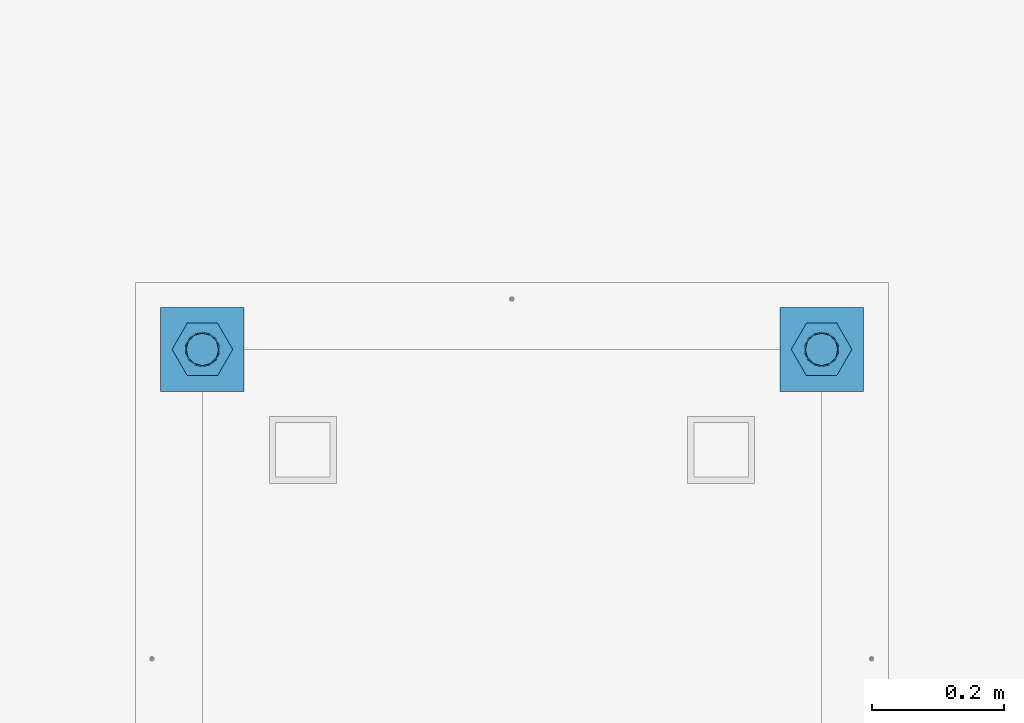
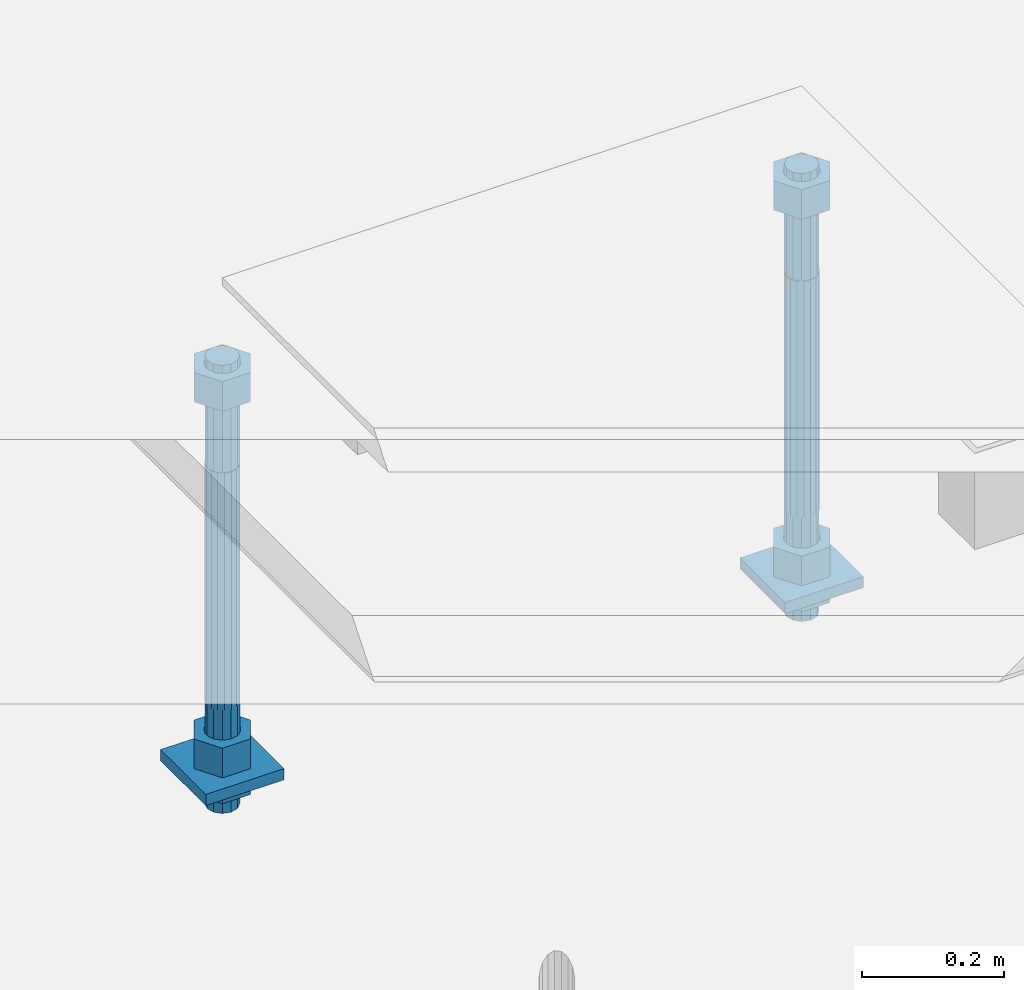
# One storey, part 2583 of 3843: 10 beams, 1 element without a shape of its own.
"""IFC2X3 building model written with IfcOpenShell, lengths in millimetres."""

from ifc_helpers import new_model, si_unit, frame, origin_with_axes, place, context, subcontext, project, spatial, faceted_brep, material, type_object, element, aggregate, save


model = new_model("IFC2X3")

# Units and contexts
model_context = context("Model", 3, precision=1e-05, world=origin_with_axes())
body_context = subcontext(model_context, "Body", "Model", "MODEL_VIEW")
ifc_project = project(units=[si_unit("LENGTHUNIT", "METRE", prefix="MILLI"), si_unit("AREAUNIT", "SQUARE_METRE"), si_unit("VOLUMEUNIT", "CUBIC_METRE"), si_unit("MASSUNIT", "GRAM", prefix="KILO"), si_unit("TIMEUNIT", "SECOND"), si_unit("PLANEANGLEUNIT", "RADIAN"), si_unit("SOLIDANGLEUNIT", "STERADIAN"), si_unit("THERMODYNAMICTEMPERATUREUNIT", "DEGREE_CELSIUS"), si_unit("LUMINOUSINTENSITYUNIT", "LUMEN")], contexts=[model_context])

# Site, building, storey
site_placement = place(None, origin_with_axes())
site = spatial("IfcSite", under=ifc_project, at=site_placement, CompositionType="ELEMENT")
building_placement = place(site_placement, origin_with_axes())
building = spatial("IfcBuilding", under=site, at=building_placement, Name="Undefined", CompositionType="ELEMENT")
storey_placement = place(building_placement, origin_with_axes())
storey = spatial("IfcBuildingStorey", under=building, at=storey_placement, Name="Undefined", CompositionType="ELEMENT", Elevation=0.0)

# Assembly, beams
assembly_placement = place(storey_placement, origin_with_axes())
assembly = element("IfcElementAssembly", 1, at=assembly_placement, inside=storey, Name="TEMPLATE", AssemblyPlace="NOTDEFINED", PredefinedType="RIGID_FRAME")
ifc_material_1 = material(Name="STEEL/A36")
beam_type_1 = type_object("IfcBeamType", PredefinedType="NOTDEFINED")
beam_1_placement = place(assembly_placement, frame((108483.4, 15176.5000015259, 29244.925), z_axis=(1.0, 0.0, 0.0), x_axis=(0.0, 1.0, 0.0)))
beam_1 = element("IfcBeam", 2, at=beam_1_placement, type_object=beam_type_1, material=ifc_material_1, Name="WASHER_PLATE", context=body_context, shape_type="Brep", body=[
    faceted_brep([(0.0, 9.52500000000146, -63.5), (0.0, 9.52500000000146, 63.5), (127.0, 9.52500000000146, 63.5), (127.0, 9.52500000000146, -63.5), (0.0, -9.52500000000146, 63.5), (127.0, -9.52500000000146, 63.5), (0.0, -9.52500000000146, -63.5), (127.0, -9.52500000000146, -63.5)], [[[0, 1, 2, 3]], [[1, 4, 5, 2]], [[4, 6, 7, 5]], [[6, 0, 3, 7]], [[5, 7, 3, 2]], [[6, 4, 1, 0]]]),
])
beam_2_placement = place(assembly_placement, frame((109423.2, 15176.5000015259, 29244.925), z_axis=(1.0, 0.0, 0.0), x_axis=(0.0, 1.0, 0.0)))
beam_2 = element("IfcBeam", 3, at=beam_2_placement, type_object=beam_type_1, material=ifc_material_1, Name="WASHER_PLATE", context=body_context, shape_type="Brep", body=[
    faceted_brep([(0.0, 9.52500000000146, -63.5), (0.0, 9.52500000000146, 63.5), (127.0, 9.52500000000146, 63.5), (127.0, 9.52500000000146, -63.5), (0.0, -9.52500000000146, 63.5), (127.0, -9.52500000000146, 63.5), (0.0, -9.52500000000146, -63.5), (127.0, -9.52500000000146, -63.5)], [[[0, 1, 2, 3]], [[1, 4, 5, 2]], [[4, 6, 7, 5]], [[6, 0, 3, 7]], [[5, 7, 3, 2]], [[6, 4, 1, 0]]]),
])
beam_type_2 = type_object("IfcBeamType", Name="2_HALF_NUT", PredefinedType="NOTDEFINED")
beam_3_placement = place(assembly_placement, frame((108483.4, 15240.0000015259, 29235.4), z_axis=(0.0, -1.0, 0.0), x_axis=(0.0, 0.0, -1.0)))
beam_3 = element("IfcBeam", 4, at=beam_3_placement, type_object=beam_type_2, material=ifc_material_1, Name="NUT", ObjectType="2_HALF_NUT", context=body_context, shape_type="Brep", body=[
    faceted_brep([(0.0, -46.0369987487793, 0.0), (0.0, -23.0184993743896, -39.869213104248), (25.4000000000015, -23.0184993743896, -39.869213104248), (25.4000000000015, -46.0369987487793, 0.0), (0.0, 23.0184993743896, -39.869213104248), (25.4000000000015, 23.0184993743896, -39.869213104248), (0.0, 46.0369987487793, 0.0), (25.4000000000015, 46.0369987487793, 0.0), (0.0, 23.0184993743896, 39.869213104248), (25.4000000000015, 23.0184993743896, 39.869213104248), (0.0, -23.0184993743896, 39.869213104248), (25.4000000000015, -23.0184993743896, 39.869213104248), (0.0, 0.0, 26.1940002441406), (0.0, 11.3650617044477, 23.5999013092805), (25.4000000000015, 11.3650617044477, 23.5999013092805), (25.4000000000015, 0.0, 26.1940002441406), (0.0, 20.4791109456419, 16.3316083006721), (25.4000000000015, 20.4791109456419, 16.3316083006721), (0.0, 25.5370200498292, 5.82867859874386), (25.4000000000015, 25.5370200498292, 5.82867859874386), (0.0, 25.5370200498292, -5.82867859874386), (25.4000000000015, 25.5370200498292, -5.82867859874386), (0.0, 20.4791109456419, -16.3316083006721), (25.4000000000015, 20.4791109456419, -16.3316083006721), (0.0, 11.3650617044477, -23.5999013092805), (25.4000000000015, 11.3650617044477, -23.5999013092805), (0.0, 0.0, -26.1940002441406), (25.4000000000015, 0.0, -26.1940002441406), (0.0, -11.3650617044477, -23.5999013092805), (25.4000000000015, -11.3650617044477, -23.5999013092805), (0.0, -20.4791109456419, -16.3316083006721), (25.4000000000015, -20.4791109456419, -16.3316083006721), (0.0, -25.5370200498292, -5.82867859874386), (25.4000000000015, -25.5370200498292, -5.82867859874386), (0.0, -25.5370200498292, 5.82867859874386), (25.4000000000015, -25.5370200498292, 5.82867859874386), (0.0, -20.4791109456419, 16.3316083006721), (25.4000000000015, -20.4791109456419, 16.3316083006721), (0.0, -11.3650617044477, 23.5999013092805), (25.4000000000015, -11.3650617044477, 23.5999013092805)], [[[0, 1, 2, 3]], [[1, 4, 5, 2]], [[4, 6, 7, 5]], [[6, 8, 9, 7]], [[8, 10, 11, 9]], [[10, 0, 3, 11]], [[12, 13, 14, 15]], [[13, 16, 17, 14]], [[16, 18, 19, 17]], [[18, 20, 21, 19]], [[20, 22, 23, 21]], [[22, 24, 25, 23]], [[24, 26, 27, 25]], [[26, 28, 29, 27]], [[28, 30, 31, 29]], [[30, 32, 33, 31]], [[32, 34, 35, 33]], [[34, 36, 37, 35]], [[36, 38, 39, 37]], [[38, 12, 15, 39]], [[5, 7, 9, 11, 3, 2], [17, 19, 21, 23, 25, 27, 29, 31, 33, 35, 37, 39, 15, 14]], [[10, 8, 6, 4, 1, 0], [38, 36, 34, 32, 30, 28, 26, 24, 22, 20, 18, 16, 13, 12]]]),
])
beam_4_placement = place(assembly_placement, frame((109423.2, 15240.0000015259, 29235.4), z_axis=(0.0, 1.0, 0.0), x_axis=(0.0, 0.0, -1.0)))
beam_4 = element("IfcBeam", 5, at=beam_4_placement, type_object=beam_type_2, material=ifc_material_1, Name="NUT", ObjectType="2_HALF_NUT", context=body_context, shape_type="Brep", body=[
    faceted_brep([(0.0, -46.0369987487793, 0.0), (0.0, -23.0184993743896, -39.869213104248), (25.4000000000015, -23.0184993743896, -39.869213104248), (25.4000000000015, -46.0369987487793, 0.0), (0.0, 23.0184993743896, -39.869213104248), (25.4000000000015, 23.0184993743896, -39.869213104248), (0.0, 46.0369987487793, 0.0), (25.4000000000015, 46.0369987487793, 0.0), (0.0, 23.0184993743896, 39.869213104248), (25.4000000000015, 23.0184993743896, 39.869213104248), (0.0, -23.0184993743896, 39.869213104248), (25.4000000000015, -23.0184993743896, 39.869213104248), (0.0, 0.0, 26.1940002441406), (0.0, 11.3650617044477, 23.5999013092805), (25.4000000000015, 11.3650617044477, 23.5999013092805), (25.4000000000015, 0.0, 26.1940002441406), (0.0, 20.4791109456419, 16.3316083006721), (25.4000000000015, 20.4791109456419, 16.3316083006721), (0.0, 25.5370200498292, 5.82867859874386), (25.4000000000015, 25.5370200498292, 5.82867859874386), (0.0, 25.5370200498292, -5.82867859874386), (25.4000000000015, 25.5370200498292, -5.82867859874386), (0.0, 20.4791109456419, -16.3316083006721), (25.4000000000015, 20.4791109456419, -16.3316083006721), (0.0, 11.3650617044477, -23.5999013092805), (25.4000000000015, 11.3650617044477, -23.5999013092805), (0.0, 0.0, -26.1940002441406), (25.4000000000015, 0.0, -26.1940002441406), (0.0, -11.3650617044477, -23.5999013092805), (25.4000000000015, -11.3650617044477, -23.5999013092805), (0.0, -20.4791109456419, -16.3316083006721), (25.4000000000015, -20.4791109456419, -16.3316083006721), (0.0, -25.5370200498292, -5.82867859874386), (25.4000000000015, -25.5370200498292, -5.82867859874386), (0.0, -25.5370200498292, 5.82867859874386), (25.4000000000015, -25.5370200498292, 5.82867859874386), (0.0, -20.4791109456419, 16.3316083006721), (25.4000000000015, -20.4791109456419, 16.3316083006721), (0.0, -11.3650617044477, 23.5999013092805), (25.4000000000015, -11.3650617044477, 23.5999013092805)], [[[0, 1, 2, 3]], [[1, 4, 5, 2]], [[4, 6, 7, 5]], [[6, 8, 9, 7]], [[8, 10, 11, 9]], [[10, 0, 3, 11]], [[12, 13, 14, 15]], [[13, 16, 17, 14]], [[16, 18, 19, 17]], [[18, 20, 21, 19]], [[20, 22, 23, 21]], [[22, 24, 25, 23]], [[24, 26, 27, 25]], [[26, 28, 29, 27]], [[28, 30, 31, 29]], [[30, 32, 33, 31]], [[32, 34, 35, 33]], [[34, 36, 37, 35]], [[36, 38, 39, 37]], [[38, 12, 15, 39]], [[5, 7, 9, 11, 3, 2], [17, 19, 21, 23, 25, 27, 29, 31, 33, 35, 37, 39, 15, 14]], [[10, 8, 6, 4, 1, 0], [38, 36, 34, 32, 30, 28, 26, 24, 22, 20, 18, 16, 13, 12]]]),
])
beam_type_3 = type_object("IfcBeamType", Name="2_HEAVY_HEX_NUT", PredefinedType="NOTDEFINED")
beam_5_placement = place(assembly_placement, frame((108483.4, 15240.0000015259, 29933.9), z_axis=(0.0, -1.0, 0.0), x_axis=(0.0, 0.0, -1.0)))
beam_5 = element("IfcBeam", 6, at=beam_5_placement, type_object=beam_type_3, material=ifc_material_1, Name="NUT", ObjectType="2_HEAVY_HEX_NUT", context=body_context, shape_type="Brep", body=[
    faceted_brep([(0.0, -46.0369987487793, 0.0), (0.0, -23.0184993743896, -39.869213104248), (50.7999999999993, -23.0184993743896, -39.869213104248), (50.7999999999993, -46.0369987487793, 0.0), (0.0, 23.0184993743896, -39.869213104248), (50.7999999999993, 23.0184993743896, -39.869213104248), (0.0, 46.0369987487793, 0.0), (50.7999999999993, 46.0369987487793, 0.0), (0.0, 23.0184993743896, 39.869213104248), (50.7999999999993, 23.0184993743896, 39.869213104248), (0.0, -23.0184993743896, 39.869213104248), (50.7999999999993, -23.0184993743896, 39.869213104248), (0.0, 0.0, 26.1940002441406), (0.0, 11.3650617044477, 23.5999013092805), (50.7999999999993, 11.3650617044477, 23.5999013092805), (50.7999999999993, 0.0, 26.1940002441406), (0.0, 20.4791109456419, 16.3316083006721), (50.7999999999993, 20.4791109456419, 16.3316083006721), (0.0, 25.5370200498292, 5.82867859874386), (50.7999999999993, 25.5370200498292, 5.82867859874386), (0.0, 25.5370200498292, -5.82867859874386), (50.7999999999993, 25.5370200498292, -5.82867859874386), (0.0, 20.4791109456419, -16.3316083006721), (50.7999999999993, 20.4791109456419, -16.3316083006721), (0.0, 11.3650617044477, -23.5999013092805), (50.7999999999993, 11.3650617044477, -23.5999013092805), (0.0, 0.0, -26.1940002441406), (50.7999999999993, 0.0, -26.1940002441406), (0.0, -11.3650617044477, -23.5999013092805), (50.7999999999993, -11.3650617044477, -23.5999013092805), (0.0, -20.4791109456419, -16.3316083006721), (50.7999999999993, -20.4791109456419, -16.3316083006721), (0.0, -25.5370200498292, -5.82867859874386), (50.7999999999993, -25.5370200498292, -5.82867859874386), (0.0, -25.5370200498292, 5.82867859874386), (50.7999999999993, -25.5370200498292, 5.82867859874386), (0.0, -20.4791109456419, 16.3316083006721), (50.7999999999993, -20.4791109456419, 16.3316083006721), (0.0, -11.3650617044477, 23.5999013092805), (50.7999999999993, -11.3650617044477, 23.5999013092805)], [[[0, 1, 2, 3]], [[1, 4, 5, 2]], [[4, 6, 7, 5]], [[6, 8, 9, 7]], [[8, 10, 11, 9]], [[10, 0, 3, 11]], [[12, 13, 14, 15]], [[13, 16, 17, 14]], [[16, 18, 19, 17]], [[18, 20, 21, 19]], [[20, 22, 23, 21]], [[22, 24, 25, 23]], [[24, 26, 27, 25]], [[26, 28, 29, 27]], [[28, 30, 31, 29]], [[30, 32, 33, 31]], [[32, 34, 35, 33]], [[34, 36, 37, 35]], [[36, 38, 39, 37]], [[38, 12, 15, 39]], [[5, 7, 9, 11, 3, 2], [17, 19, 21, 23, 25, 27, 29, 31, 33, 35, 37, 39, 15, 14]], [[10, 8, 6, 4, 1, 0], [38, 36, 34, 32, 30, 28, 26, 24, 22, 20, 18, 16, 13, 12]]]),
])
beam_6_placement = place(assembly_placement, frame((108483.4, 15240.0000015259, 29305.25), z_axis=(0.0, -1.0, 0.0), x_axis=(0.0, 0.0, -1.0)))
beam_6 = element("IfcBeam", 7, at=beam_6_placement, type_object=beam_type_3, material=ifc_material_1, Name="NUT", ObjectType="2_HEAVY_HEX_NUT", context=body_context, shape_type="Brep", body=[
    faceted_brep([(0.0, -46.0369987487793, 0.0), (0.0, -23.0184993743896, -39.869213104248), (50.7999999999993, -23.0184993743896, -39.869213104248), (50.7999999999993, -46.0369987487793, 0.0), (0.0, 23.0184993743896, -39.869213104248), (50.7999999999993, 23.0184993743896, -39.869213104248), (0.0, 46.0369987487793, 0.0), (50.7999999999993, 46.0369987487793, 0.0), (0.0, 23.0184993743896, 39.869213104248), (50.7999999999993, 23.0184993743896, 39.869213104248), (0.0, -23.0184993743896, 39.869213104248), (50.7999999999993, -23.0184993743896, 39.869213104248), (0.0, 0.0, 26.1940002441406), (0.0, 11.3650617044477, 23.5999013092805), (50.7999999999993, 11.3650617044477, 23.5999013092805), (50.7999999999993, 0.0, 26.1940002441406), (0.0, 20.4791109456419, 16.3316083006721), (50.7999999999993, 20.4791109456419, 16.3316083006721), (0.0, 25.5370200498292, 5.82867859874386), (50.7999999999993, 25.5370200498292, 5.82867859874386), (0.0, 25.5370200498292, -5.82867859874386), (50.7999999999993, 25.5370200498292, -5.82867859874386), (0.0, 20.4791109456419, -16.3316083006721), (50.7999999999993, 20.4791109456419, -16.3316083006721), (0.0, 11.3650617044477, -23.5999013092805), (50.7999999999993, 11.3650617044477, -23.5999013092805), (0.0, 0.0, -26.1940002441406), (50.7999999999993, 0.0, -26.1940002441406), (0.0, -11.3650617044477, -23.5999013092805), (50.7999999999993, -11.3650617044477, -23.5999013092805), (0.0, -20.4791109456419, -16.3316083006721), (50.7999999999993, -20.4791109456419, -16.3316083006721), (0.0, -25.5370200498292, -5.82867859874386), (50.7999999999993, -25.5370200498292, -5.82867859874386), (0.0, -25.5370200498292, 5.82867859874386), (50.7999999999993, -25.5370200498292, 5.82867859874386), (0.0, -20.4791109456419, 16.3316083006721), (50.7999999999993, -20.4791109456419, 16.3316083006721), (0.0, -11.3650617044477, 23.5999013092805), (50.7999999999993, -11.3650617044477, 23.5999013092805)], [[[0, 1, 2, 3]], [[1, 4, 5, 2]], [[4, 6, 7, 5]], [[6, 8, 9, 7]], [[8, 10, 11, 9]], [[10, 0, 3, 11]], [[12, 13, 14, 15]], [[13, 16, 17, 14]], [[16, 18, 19, 17]], [[18, 20, 21, 19]], [[20, 22, 23, 21]], [[22, 24, 25, 23]], [[24, 26, 27, 25]], [[26, 28, 29, 27]], [[28, 30, 31, 29]], [[30, 32, 33, 31]], [[32, 34, 35, 33]], [[34, 36, 37, 35]], [[36, 38, 39, 37]], [[38, 12, 15, 39]], [[5, 7, 9, 11, 3, 2], [17, 19, 21, 23, 25, 27, 29, 31, 33, 35, 37, 39, 15, 14]], [[10, 8, 6, 4, 1, 0], [38, 36, 34, 32, 30, 28, 26, 24, 22, 20, 18, 16, 13, 12]]]),
])
beam_7_placement = place(assembly_placement, frame((109423.2, 15240.0000015259, 29933.9), z_axis=(0.0, 1.0, 0.0), x_axis=(0.0, 0.0, -1.0)))
beam_7 = element("IfcBeam", 8, at=beam_7_placement, type_object=beam_type_3, material=ifc_material_1, Name="NUT", ObjectType="2_HEAVY_HEX_NUT", context=body_context, shape_type="Brep", body=[
    faceted_brep([(0.0, -46.0369987487793, 0.0), (0.0, -23.0184993743896, -39.869213104248), (50.7999999999993, -23.0184993743896, -39.869213104248), (50.7999999999993, -46.0369987487793, 0.0), (0.0, 23.0184993743896, -39.869213104248), (50.7999999999993, 23.0184993743896, -39.869213104248), (0.0, 46.0369987487793, 0.0), (50.7999999999993, 46.0369987487793, 0.0), (0.0, 23.0184993743896, 39.869213104248), (50.7999999999993, 23.0184993743896, 39.869213104248), (0.0, -23.0184993743896, 39.869213104248), (50.7999999999993, -23.0184993743896, 39.869213104248), (0.0, 0.0, 26.1940002441406), (0.0, 11.3650617044477, 23.5999013092805), (50.7999999999993, 11.3650617044477, 23.5999013092805), (50.7999999999993, 0.0, 26.1940002441406), (0.0, 20.4791109456419, 16.3316083006721), (50.7999999999993, 20.4791109456419, 16.3316083006721), (0.0, 25.5370200498292, 5.82867859874386), (50.7999999999993, 25.5370200498292, 5.82867859874386), (0.0, 25.5370200498292, -5.82867859874386), (50.7999999999993, 25.5370200498292, -5.82867859874386), (0.0, 20.4791109456419, -16.3316083006721), (50.7999999999993, 20.4791109456419, -16.3316083006721), (0.0, 11.3650617044477, -23.5999013092805), (50.7999999999993, 11.3650617044477, -23.5999013092805), (0.0, 0.0, -26.1940002441406), (50.7999999999993, 0.0, -26.1940002441406), (0.0, -11.3650617044477, -23.5999013092805), (50.7999999999993, -11.3650617044477, -23.5999013092805), (0.0, -20.4791109456419, -16.3316083006721), (50.7999999999993, -20.4791109456419, -16.3316083006721), (0.0, -25.5370200498292, -5.82867859874386), (50.7999999999993, -25.5370200498292, -5.82867859874386), (0.0, -25.5370200498292, 5.82867859874386), (50.7999999999993, -25.5370200498292, 5.82867859874386), (0.0, -20.4791109456419, 16.3316083006721), (50.7999999999993, -20.4791109456419, 16.3316083006721), (0.0, -11.3650617044477, 23.5999013092805), (50.7999999999993, -11.3650617044477, 23.5999013092805)], [[[0, 1, 2, 3]], [[1, 4, 5, 2]], [[4, 6, 7, 5]], [[6, 8, 9, 7]], [[8, 10, 11, 9]], [[10, 0, 3, 11]], [[12, 13, 14, 15]], [[13, 16, 17, 14]], [[16, 18, 19, 17]], [[18, 20, 21, 19]], [[20, 22, 23, 21]], [[22, 24, 25, 23]], [[24, 26, 27, 25]], [[26, 28, 29, 27]], [[28, 30, 31, 29]], [[30, 32, 33, 31]], [[32, 34, 35, 33]], [[34, 36, 37, 35]], [[36, 38, 39, 37]], [[38, 12, 15, 39]], [[5, 7, 9, 11, 3, 2], [17, 19, 21, 23, 25, 27, 29, 31, 33, 35, 37, 39, 15, 14]], [[10, 8, 6, 4, 1, 0], [38, 36, 34, 32, 30, 28, 26, 24, 22, 20, 18, 16, 13, 12]]]),
])
beam_8_placement = place(assembly_placement, frame((109423.2, 15240.0000015259, 29305.25), z_axis=(0.0, 1.0, 0.0), x_axis=(0.0, 0.0, -1.0)))
beam_8 = element("IfcBeam", 9, at=beam_8_placement, type_object=beam_type_3, material=ifc_material_1, Name="NUT", ObjectType="2_HEAVY_HEX_NUT", context=body_context, shape_type="Brep", body=[
    faceted_brep([(0.0, -46.0369987487793, 0.0), (0.0, -23.0184993743896, -39.869213104248), (50.7999999999993, -23.0184993743896, -39.869213104248), (50.7999999999993, -46.0369987487793, 0.0), (0.0, 23.0184993743896, -39.869213104248), (50.7999999999993, 23.0184993743896, -39.869213104248), (0.0, 46.0369987487793, 0.0), (50.7999999999993, 46.0369987487793, 0.0), (0.0, 23.0184993743896, 39.869213104248), (50.7999999999993, 23.0184993743896, 39.869213104248), (0.0, -23.0184993743896, 39.869213104248), (50.7999999999993, -23.0184993743896, 39.869213104248), (0.0, 0.0, 26.1940002441406), (0.0, 11.3650617044477, 23.5999013092805), (50.7999999999993, 11.3650617044477, 23.5999013092805), (50.7999999999993, 0.0, 26.1940002441406), (0.0, 20.4791109456419, 16.3316083006721), (50.7999999999993, 20.4791109456419, 16.3316083006721), (0.0, 25.5370200498292, 5.82867859874386), (50.7999999999993, 25.5370200498292, 5.82867859874386), (0.0, 25.5370200498292, -5.82867859874386), (50.7999999999993, 25.5370200498292, -5.82867859874386), (0.0, 20.4791109456419, -16.3316083006721), (50.7999999999993, 20.4791109456419, -16.3316083006721), (0.0, 11.3650617044477, -23.5999013092805), (50.7999999999993, 11.3650617044477, -23.5999013092805), (0.0, 0.0, -26.1940002441406), (50.7999999999993, 0.0, -26.1940002441406), (0.0, -11.3650617044477, -23.5999013092805), (50.7999999999993, -11.3650617044477, -23.5999013092805), (0.0, -20.4791109456419, -16.3316083006721), (50.7999999999993, -20.4791109456419, -16.3316083006721), (0.0, -25.5370200498292, -5.82867859874386), (50.7999999999993, -25.5370200498292, -5.82867859874386), (0.0, -25.5370200498292, 5.82867859874386), (50.7999999999993, -25.5370200498292, 5.82867859874386), (0.0, -20.4791109456419, 16.3316083006721), (50.7999999999993, -20.4791109456419, 16.3316083006721), (0.0, -11.3650617044477, 23.5999013092805), (50.7999999999993, -11.3650617044477, 23.5999013092805)], [[[0, 1, 2, 3]], [[1, 4, 5, 2]], [[4, 6, 7, 5]], [[6, 8, 9, 7]], [[8, 10, 11, 9]], [[10, 0, 3, 11]], [[12, 13, 14, 15]], [[13, 16, 17, 14]], [[16, 18, 19, 17]], [[18, 20, 21, 19]], [[20, 22, 23, 21]], [[22, 24, 25, 23]], [[24, 26, 27, 25]], [[26, 28, 29, 27]], [[28, 30, 31, 29]], [[30, 32, 33, 31]], [[32, 34, 35, 33]], [[34, 36, 37, 35]], [[36, 38, 39, 37]], [[38, 12, 15, 39]], [[5, 7, 9, 11, 3, 2], [17, 19, 21, 23, 25, 27, 29, 31, 33, 35, 37, 39, 15, 14]], [[10, 8, 6, 4, 1, 0], [38, 36, 34, 32, 30, 28, 26, 24, 22, 20, 18, 16, 13, 12]]]),
])
ifc_material_2 = material()
beam_type_4 = type_object("IfcBeamType", PredefinedType="NOTDEFINED")
beam_9_placement = place(assembly_placement, frame((108483.4, 15240.0000015259, 29762.45), z_axis=(0.0, -1.0, 0.0), x_axis=(0.0, 0.0, -1.0)))
beam_9 = element("IfcBeam", 10, at=beam_9_placement, type_object=beam_type_4, material=ifc_material_2, Name="ANCHOR_ROD", context=body_context, shape_type="Brep", body=[
    faceted_brep([(-184.150000000001, -21.217622392709, 12.25), (-184.150000000001, -12.2499999999854, 21.2176223927163), (-184.150000000001, 1.45519152283669e-11, 24.5), (-184.150000000001, 12.2500000000146, 21.2176223927163), (-184.150000000001, 21.2176223927381, 12.25), (-184.150000000001, 24.5000000000146, 0.0), (-184.150000000001, 21.2176223927381, -12.25), (-184.150000000001, 12.2500000000146, -21.2176223927163), (-184.150000000001, 1.45519152283669e-11, -24.5), (-184.150000000001, -12.2499999999854, -21.2176223927163), (-184.150000000001, -21.217622392709, -12.25), (-184.150000000001, -24.4999999999854, 0.0), (0.0, 24.5000000000146, 0.0), (0.0, 21.2176223927381, -12.25), (0.0, 12.2500000000146, -21.2176223927163), (0.0, 1.45519152283669e-11, -24.5), (0.0, -12.2499999999854, -21.2176223927163), (0.0, -21.217622392709, -12.25), (0.0, -24.4999999999854, 0.0), (0.0, -21.217622392709, 12.25), (0.0, -12.2499999999854, 21.2176223927163), (0.0, 1.45519152283669e-11, 24.5), (0.0, 12.2500000000146, 21.2176223927163), (0.0, 21.2176223927381, 12.25), (0.0, -23.4665401257807, 9.72015918207035), (0.0, -17.9605122421344, 17.9605122421417), (0.0, -9.72015918207762, 23.466540125788), (0.0, 0.0, 25.4000000000015), (0.0, 9.72015918207762, 23.466540125788), (0.0, 17.9605122421344, 17.9605122421417), (0.0, 23.4665401257807, 9.72015918207035), (0.0, 25.3999996185303, 0.0), (0.0, 23.4665401257807, -9.72015918207035), (0.0, 17.9605122421344, -17.9605122421417), (0.0, 9.72015918207762, -23.466540125788), (0.0, 0.0, -25.4000000000015), (0.0, -9.72015918207762, -23.466540125788), (0.0, -17.9605122421344, -17.9605122421417), (0.0, -23.4665401257807, -9.72015918207035), (0.0, -25.3999996185303, 0.0), (406.399999999998, -25.3999999999942, 0.0), (406.399999999998, -23.4665401257807, 9.72015918207035), (406.399999999998, -17.9605122421344, 17.9605122421417), (406.399999999998, -9.72015918207762, 23.466540125788), (406.399999999998, 0.0, 25.4000000000015), (406.399999999998, 9.72015918207762, 23.466540125788), (406.399999999998, 17.9605122421344, 17.9605122421417), (406.399999999998, 23.4665401257807, 9.72015918207035), (406.399999999998, 25.3999999999942, 0.0), (406.399999999998, 23.4665401257807, -9.72015918207035), (406.399999999998, 17.9605122421344, -17.9605122421417), (406.399999999998, 9.72015918207762, -23.466540125788), (406.399999999998, 0.0, -25.4000000000015), (406.399999999998, -9.72015918207762, -23.466540125788), (406.399999999998, -17.9605122421344, -17.9605122421417), (406.399999999998, -23.4665401257807, -9.72015918207035), (406.399999999998, -12.2499999999854, 21.2176223927163), (406.399999999998, 1.45519152283669e-11, 24.5), (406.399999999998, 12.2500000000146, 21.2176223927163), (406.399999999998, 21.2176223927381, 12.25), (406.399999999998, 24.5000000000146, 0.0), (406.399999999998, 21.2176223927381, -12.25), (406.399999999998, 12.2500000000146, -21.2176223927163), (406.399999999998, 1.45519152283669e-11, -24.5), (406.399999999998, -12.2499999999854, -21.2176223927163), (406.399999999998, -21.217622392709, -12.25), (406.399999999998, -24.4999999999854, 0.0), (406.399999999998, -21.217622392709, 12.25), (584.200000000001, -12.2499999999854, -21.2176223927163), (584.200000000001, 1.45519152283669e-11, -24.5), (584.200000000001, 12.2500000000146, -21.2176223927163), (584.200000000001, 21.2176223927381, -12.25), (584.200000000001, 24.5000000000146, 0.0), (584.200000000001, 21.2176223927381, 12.25), (584.200000000001, 12.2500000000146, 21.2176223927163), (584.200000000001, 1.45519152283669e-11, 24.5), (584.200000000001, -12.2499999999854, 21.2176223927163), (584.200000000001, -21.217622392709, 12.25), (584.200000000001, -24.4999999999854, 0.0), (584.200000000001, -21.217622392709, -12.25)], [[[0, 1, 2, 3, 4, 5, 6, 7, 8, 9, 10, 11]], [[6, 5, 12, 13]], [[7, 6, 13, 14]], [[8, 7, 14, 15]], [[9, 8, 15, 16]], [[10, 9, 16, 17]], [[11, 10, 17, 18]], [[0, 11, 18, 19]], [[1, 0, 19, 20]], [[2, 1, 20, 21]], [[3, 2, 21, 22]], [[4, 3, 22, 23]], [[5, 4, 23, 12]], [[24, 25, 26, 27, 28, 29, 30, 31, 32, 33, 34, 35, 36, 37, 38, 39], [22, 21, 20, 19, 18, 17, 16, 15, 14, 13, 12, 23]], [[24, 39, 40, 41]], [[25, 24, 41, 42]], [[26, 25, 42, 43]], [[27, 26, 43, 44]], [[28, 27, 44, 45]], [[29, 28, 45, 46]], [[30, 29, 46, 47]], [[31, 30, 47, 48]], [[32, 31, 48, 49]], [[33, 32, 49, 50]], [[34, 33, 50, 51]], [[35, 34, 51, 52]], [[36, 35, 52, 53]], [[37, 36, 53, 54]], [[38, 37, 54, 55]], [[39, 38, 55, 40]], [[54, 53, 52, 51, 50, 49, 48, 47, 46, 45, 44, 43, 42, 41, 40, 55], [56, 57, 58, 59, 60, 61, 62, 63, 64, 65, 66, 67]], [[68, 69, 70, 71, 72, 73, 74, 75, 76, 77, 78, 79]], [[76, 75, 57, 56]], [[77, 76, 56, 67]], [[78, 77, 67, 66]], [[79, 78, 66, 65]], [[68, 79, 65, 64]], [[69, 68, 64, 63]], [[70, 69, 63, 62]], [[71, 70, 62, 61]], [[72, 71, 61, 60]], [[73, 72, 60, 59]], [[74, 73, 59, 58]], [[75, 74, 58, 57]]]),
])
beam_10_placement = place(assembly_placement, frame((109423.2, 15240.0000015259, 29762.45), z_axis=(0.0, 1.0, 0.0), x_axis=(0.0, 0.0, -1.0)))
beam_10 = element("IfcBeam", 11, at=beam_10_placement, type_object=beam_type_4, material=ifc_material_2, Name="ANCHOR_ROD", context=body_context, shape_type="Brep", body=[
    faceted_brep([(-184.150000000001, -21.217622392709, 12.25), (-184.150000000001, -12.2499999999854, 21.2176223927163), (-184.150000000001, 1.45519152283669e-11, 24.5), (-184.150000000001, 12.2500000000146, 21.2176223927163), (-184.150000000001, 21.2176223927381, 12.25), (-184.150000000001, 24.5000000000146, 0.0), (-184.150000000001, 21.2176223927381, -12.25), (-184.150000000001, 12.2500000000146, -21.2176223927163), (-184.150000000001, 1.45519152283669e-11, -24.5), (-184.150000000001, -12.2499999999854, -21.2176223927163), (-184.150000000001, -21.217622392709, -12.25), (-184.150000000001, -24.4999999999854, 0.0), (0.0, 24.5000000000146, 0.0), (0.0, 21.2176223927381, -12.25), (0.0, 12.2500000000146, -21.2176223927163), (0.0, 1.45519152283669e-11, -24.5), (0.0, -12.2499999999854, -21.2176223927163), (0.0, -21.217622392709, -12.25), (0.0, -24.4999999999854, 0.0), (0.0, -21.217622392709, 12.25), (0.0, -12.2499999999854, 21.2176223927163), (0.0, 1.45519152283669e-11, 24.5), (0.0, 12.2500000000146, 21.2176223927163), (0.0, 21.2176223927381, 12.25), (0.0, -23.4665401257807, 9.72015918207035), (0.0, -17.9605122421344, 17.9605122421417), (0.0, -9.72015918207762, 23.466540125788), (0.0, 0.0, 25.4000000000015), (0.0, 9.72015918207762, 23.466540125788), (0.0, 17.9605122421344, 17.9605122421417), (0.0, 23.4665401257807, 9.72015918207035), (0.0, 25.3999996185303, 0.0), (0.0, 23.4665401257807, -9.72015918207035), (0.0, 17.9605122421344, -17.9605122421417), (0.0, 9.72015918207762, -23.466540125788), (0.0, 0.0, -25.4000000000015), (0.0, -9.72015918207762, -23.466540125788), (0.0, -17.9605122421344, -17.9605122421417), (0.0, -23.4665401257807, -9.72015918207035), (0.0, -25.3999996185303, 0.0), (406.399999999998, -25.3999999999942, 0.0), (406.399999999998, -23.4665401257807, 9.72015918207035), (406.399999999998, -17.9605122421344, 17.9605122421417), (406.399999999998, -9.72015918207762, 23.466540125788), (406.399999999998, 0.0, 25.4000000000015), (406.399999999998, 9.72015918207762, 23.466540125788), (406.399999999998, 17.9605122421344, 17.9605122421417), (406.399999999998, 23.4665401257807, 9.72015918207035), (406.399999999998, 25.3999999999942, 0.0), (406.399999999998, 23.4665401257807, -9.72015918207035), (406.399999999998, 17.9605122421344, -17.9605122421417), (406.399999999998, 9.72015918207762, -23.466540125788), (406.399999999998, 0.0, -25.4000000000015), (406.399999999998, -9.72015918207762, -23.466540125788), (406.399999999998, -17.9605122421344, -17.9605122421417), (406.399999999998, -23.4665401257807, -9.72015918207035), (406.399999999998, -12.2499999999854, 21.2176223927163), (406.399999999998, 1.45519152283669e-11, 24.5), (406.399999999998, 12.2500000000146, 21.2176223927163), (406.399999999998, 21.2176223927381, 12.25), (406.399999999998, 24.5000000000146, 0.0), (406.399999999998, 21.2176223927381, -12.25), (406.399999999998, 12.2500000000146, -21.2176223927163), (406.399999999998, 1.45519152283669e-11, -24.5), (406.399999999998, -12.2499999999854, -21.2176223927163), (406.399999999998, -21.217622392709, -12.25), (406.399999999998, -24.4999999999854, 0.0), (406.399999999998, -21.217622392709, 12.25), (584.200000000001, -12.2499999999854, -21.2176223927163), (584.200000000001, 1.45519152283669e-11, -24.5), (584.200000000001, 12.2500000000146, -21.2176223927163), (584.200000000001, 21.2176223927381, -12.25), (584.200000000001, 24.5000000000146, 0.0), (584.200000000001, 21.2176223927381, 12.25), (584.200000000001, 12.2500000000146, 21.2176223927163), (584.200000000001, 1.45519152283669e-11, 24.5), (584.200000000001, -12.2499999999854, 21.2176223927163), (584.200000000001, -21.217622392709, 12.25), (584.200000000001, -24.4999999999854, 0.0), (584.200000000001, -21.217622392709, -12.25)], [[[0, 1, 2, 3, 4, 5, 6, 7, 8, 9, 10, 11]], [[6, 5, 12, 13]], [[7, 6, 13, 14]], [[8, 7, 14, 15]], [[9, 8, 15, 16]], [[10, 9, 16, 17]], [[11, 10, 17, 18]], [[0, 11, 18, 19]], [[1, 0, 19, 20]], [[2, 1, 20, 21]], [[3, 2, 21, 22]], [[4, 3, 22, 23]], [[5, 4, 23, 12]], [[24, 25, 26, 27, 28, 29, 30, 31, 32, 33, 34, 35, 36, 37, 38, 39], [22, 21, 20, 19, 18, 17, 16, 15, 14, 13, 12, 23]], [[24, 39, 40, 41]], [[25, 24, 41, 42]], [[26, 25, 42, 43]], [[27, 26, 43, 44]], [[28, 27, 44, 45]], [[29, 28, 45, 46]], [[30, 29, 46, 47]], [[31, 30, 47, 48]], [[32, 31, 48, 49]], [[33, 32, 49, 50]], [[34, 33, 50, 51]], [[35, 34, 51, 52]], [[36, 35, 52, 53]], [[37, 36, 53, 54]], [[38, 37, 54, 55]], [[39, 38, 55, 40]], [[54, 53, 52, 51, 50, 49, 48, 47, 46, 45, 44, 43, 42, 41, 40, 55], [56, 57, 58, 59, 60, 61, 62, 63, 64, 65, 66, 67]], [[68, 69, 70, 71, 72, 73, 74, 75, 76, 77, 78, 79]], [[76, 75, 57, 56]], [[77, 76, 56, 67]], [[78, 77, 67, 66]], [[79, 78, 66, 65]], [[68, 79, 65, 64]], [[69, 68, 64, 63]], [[70, 69, 63, 62]], [[71, 70, 62, 61]], [[72, 71, 61, 60]], [[73, 72, 60, 59]], [[74, 73, 59, 58]], [[75, 74, 58, 57]]]),
])
aggregate(assembly, [beam_5, beam_6, beam_3, beam_1, beam_9, beam_7, beam_8, beam_4, beam_2, beam_10])

save(model, "model.ifc")
